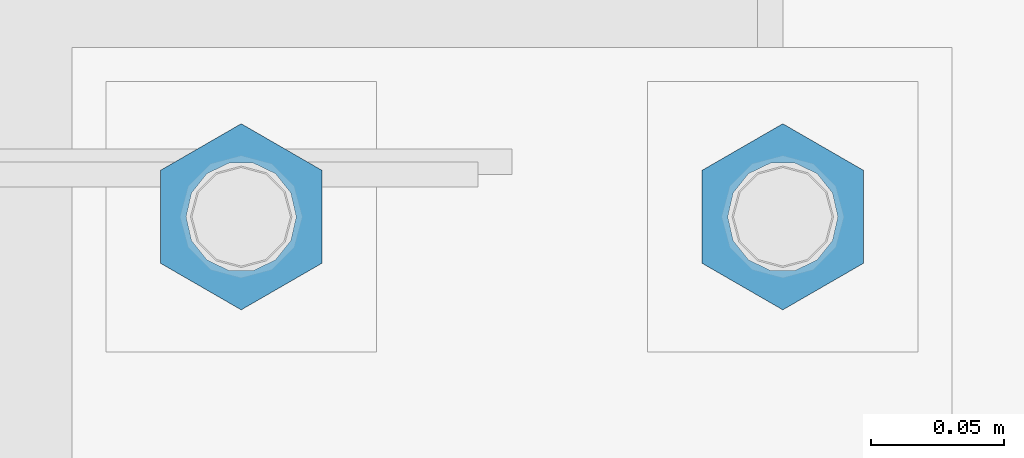
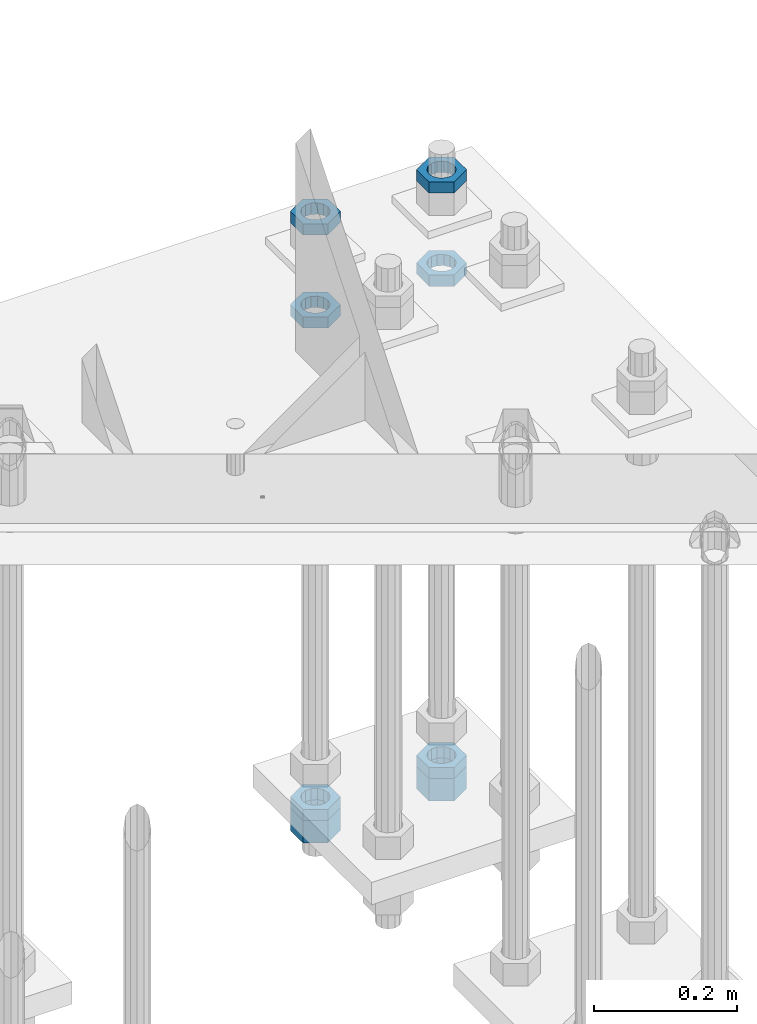
# One storey, part 2967 of 3843: 8 beams, 1 element without a shape of its own.
"""IFC2X3 building model written with IfcOpenShell, lengths in millimetres."""

from ifc_helpers import new_model, si_unit, frame, origin_with_axes, place, context, subcontext, project, spatial, faceted_brep, material, type_object, element, aggregate, save


model = new_model("IFC2X3")

# Units and contexts
model_context = context("Model", 3, precision=1e-05, world=origin_with_axes())
body_context = subcontext(model_context, "Body", "Model", "MODEL_VIEW")
ifc_project = project(units=[si_unit("LENGTHUNIT", "METRE", prefix="MILLI"), si_unit("AREAUNIT", "SQUARE_METRE"), si_unit("VOLUMEUNIT", "CUBIC_METRE"), si_unit("MASSUNIT", "GRAM", prefix="KILO"), si_unit("TIMEUNIT", "SECOND"), si_unit("PLANEANGLEUNIT", "RADIAN"), si_unit("SOLIDANGLEUNIT", "STERADIAN"), si_unit("THERMODYNAMICTEMPERATUREUNIT", "DEGREE_CELSIUS"), si_unit("LUMINOUSINTENSITYUNIT", "LUMEN")], contexts=[model_context])

# Site, building, storey
site_placement = place(None, origin_with_axes())
site = spatial("IfcSite", under=ifc_project, at=site_placement, CompositionType="ELEMENT")
building_placement = place(site_placement, origin_with_axes())
building = spatial("IfcBuilding", under=site, at=building_placement, Name="Undefined", CompositionType="ELEMENT")
storey_placement = place(building_placement, origin_with_axes())
storey = spatial("IfcBuildingStorey", under=building, at=storey_placement, Name="Undefined", CompositionType="ELEMENT", Elevation=0.0)

# Assembly, beams
assembly_placement = place(storey_placement, origin_with_axes())
assembly = element("IfcElementAssembly", 1, at=assembly_placement, inside=storey, Name="TEMPLATE", AssemblyPlace="NOTDEFINED", PredefinedType="RIGID_FRAME")
ifc_material = material(Name="STEEL/A572-50")
beam_type_1 = type_object("IfcBeamType", Name="1-1/2_HEAVY_HEX_NUT", PredefinedType="NOTDEFINED")
beam_1_placement = place(assembly_placement, frame((86156.8, 104940.1, 28746.45), z_axis=(-1.0, 0.0, 0.0), x_axis=(0.0, 0.0, -1.0)))
beam_1 = element("IfcBeam", 2, at=beam_1_placement, type_object=beam_type_1, material=ifc_material, Name="NUT", ObjectType="1-1/2_HEAVY_HEX_NUT", context=body_context, shape_type="Brep", body=[
    faceted_brep([(0.0, -34.9199981689453, 0.0), (0.0, -17.4599990844727, -30.25), (38.0999999999985, -17.4599990844727, -30.25), (38.0999999999985, -34.9199981689453, 0.0), (0.0, 17.4599990844727, -30.25), (38.0999999999985, 17.4599990844727, -30.25), (0.0, 34.9199981689453, 0.0), (38.0999999999985, 34.9199981689453, 0.0), (0.0, 17.4599990844727, 30.25), (38.0999999999985, 17.4599990844727, 30.25), (0.0, -17.4599990844727, 30.25), (38.0999999999985, -17.4599990844727, 30.25), (0.0, 0.0, 20.6399993896484), (0.0, 8.9553601105581, 18.5959968835959), (38.0999999999985, 8.9553601105581, 18.5959968835959), (38.0999999999985, 0.0, 20.6399993896484), (0.0, 16.1370013209525, 12.8688291298167), (38.0999999999985, 16.1370013209525, 12.8688291298167), (0.0, 20.1225115123816, 4.59283194104501), (38.0999999999985, 20.1225115123816, 4.59283194104501), (0.0, 20.1225115123816, -4.59283194104501), (38.0999999999985, 20.1225115123816, -4.59283194104501), (0.0, 16.1370013209525, -12.8688291298167), (38.0999999999985, 16.1370013209525, -12.8688291298167), (0.0, 8.9553601105581, -18.5959968835959), (38.0999999999985, 8.9553601105581, -18.5959968835959), (0.0, 0.0, -20.6399993896484), (38.0999999999985, 0.0, -20.6399993896484), (0.0, -8.9553601105581, -18.5959968835959), (38.0999999999985, -8.9553601105581, -18.5959968835959), (0.0, -16.1370013209525, -12.8688291298167), (38.0999999999985, -16.1370013209525, -12.8688291298167), (0.0, -20.1225115123816, -4.59283194104501), (38.0999999999985, -20.1225115123816, -4.59283194104501), (0.0, -20.1225115123816, 4.59283194104501), (38.0999999999985, -20.1225115123816, 4.59283194104501), (0.0, -16.1370013209525, 12.8688291298167), (38.0999999999985, -16.1370013209525, 12.8688291298167), (0.0, -8.9553601105581, 18.5959968835959), (38.0999999999985, -8.9553601105581, 18.5959968835959)], [[[0, 1, 2, 3]], [[1, 4, 5, 2]], [[4, 6, 7, 5]], [[6, 8, 9, 7]], [[8, 10, 11, 9]], [[10, 0, 3, 11]], [[12, 13, 14, 15]], [[13, 16, 17, 14]], [[16, 18, 19, 17]], [[18, 20, 21, 19]], [[20, 22, 23, 21]], [[22, 24, 25, 23]], [[24, 26, 27, 25]], [[26, 28, 29, 27]], [[28, 30, 31, 29]], [[30, 32, 33, 31]], [[32, 34, 35, 33]], [[34, 36, 37, 35]], [[36, 38, 39, 37]], [[38, 12, 15, 39]], [[5, 7, 9, 11, 3, 2], [17, 19, 21, 23, 25, 27, 29, 31, 33, 35, 37, 39, 15, 14]], [[10, 8, 6, 4, 1, 0], [38, 36, 34, 32, 30, 28, 26, 24, 22, 20, 18, 16, 13, 12]]]),
])
beam_2_placement = place(assembly_placement, frame((85953.6, 104940.1, 28746.45), z_axis=(-1.0, 0.0, 0.0), x_axis=(0.0, 0.0, -1.0)))
beam_2 = element("IfcBeam", 3, at=beam_2_placement, type_object=beam_type_1, material=ifc_material, Name="NUT", ObjectType="1-1/2_HEAVY_HEX_NUT", context=body_context, shape_type="Brep", body=[
    faceted_brep([(0.0, -34.9199981689453, 0.0), (0.0, -17.4599990844727, -30.25), (38.0999999999985, -17.4599990844727, -30.25), (38.0999999999985, -34.9199981689453, 0.0), (0.0, 17.4599990844727, -30.25), (38.0999999999985, 17.4599990844727, -30.25), (0.0, 34.9199981689453, 0.0), (38.0999999999985, 34.9199981689453, 0.0), (0.0, 17.4599990844727, 30.25), (38.0999999999985, 17.4599990844727, 30.25), (0.0, -17.4599990844727, 30.25), (38.0999999999985, -17.4599990844727, 30.25), (0.0, 0.0, 20.6399993896484), (0.0, 8.9553601105581, 18.5959968835959), (38.0999999999985, 8.9553601105581, 18.5959968835959), (38.0999999999985, 0.0, 20.6399993896484), (0.0, 16.1370013209525, 12.8688291298167), (38.0999999999985, 16.1370013209525, 12.8688291298167), (0.0, 20.1225115123816, 4.59283194104501), (38.0999999999985, 20.1225115123816, 4.59283194104501), (0.0, 20.1225115123816, -4.59283194104501), (38.0999999999985, 20.1225115123816, -4.59283194104501), (0.0, 16.1370013209525, -12.8688291298167), (38.0999999999985, 16.1370013209525, -12.8688291298167), (0.0, 8.9553601105581, -18.5959968835959), (38.0999999999985, 8.9553601105581, -18.5959968835959), (0.0, 0.0, -20.6399993896484), (38.0999999999985, 0.0, -20.6399993896484), (0.0, -8.9553601105581, -18.5959968835959), (38.0999999999985, -8.9553601105581, -18.5959968835959), (0.0, -16.1370013209525, -12.8688291298167), (38.0999999999985, -16.1370013209525, -12.8688291298167), (0.0, -20.1225115123816, -4.59283194104501), (38.0999999999985, -20.1225115123816, -4.59283194104501), (0.0, -20.1225115123816, 4.59283194104501), (38.0999999999985, -20.1225115123816, 4.59283194104501), (0.0, -16.1370013209525, 12.8688291298167), (38.0999999999985, -16.1370013209525, 12.8688291298167), (0.0, -8.9553601105581, 18.5959968835959), (38.0999999999985, -8.9553601105581, 18.5959968835959)], [[[0, 1, 2, 3]], [[1, 4, 5, 2]], [[4, 6, 7, 5]], [[6, 8, 9, 7]], [[8, 10, 11, 9]], [[10, 0, 3, 11]], [[12, 13, 14, 15]], [[13, 16, 17, 14]], [[16, 18, 19, 17]], [[18, 20, 21, 19]], [[20, 22, 23, 21]], [[22, 24, 25, 23]], [[24, 26, 27, 25]], [[26, 28, 29, 27]], [[28, 30, 31, 29]], [[30, 32, 33, 31]], [[32, 34, 35, 33]], [[34, 36, 37, 35]], [[36, 38, 39, 37]], [[38, 12, 15, 39]], [[5, 7, 9, 11, 3, 2], [17, 19, 21, 23, 25, 27, 29, 31, 33, 35, 37, 39, 15, 14]], [[10, 8, 6, 4, 1, 0], [38, 36, 34, 32, 30, 28, 26, 24, 22, 20, 18, 16, 13, 12]]]),
])
beam_type_2 = type_object("IfcBeamType", Name="1-1/2_HALF_NUT", PredefinedType="NOTDEFINED")
beam_3_placement = place(assembly_placement, frame((86156.8, 104940.1, 29603.7), z_axis=(-1.0, 0.0, 0.0), x_axis=(0.0, 0.0, -1.0)))
beam_3 = element("IfcBeam", 4, at=beam_3_placement, type_object=beam_type_2, material=ifc_material, Name="NUT", ObjectType="1-1/2_HALF_NUT", context=body_context, shape_type="Brep", body=[
    faceted_brep([(0.0, -34.9199981689453, 0.0), (0.0, -17.4599990844727, -30.25), (19.0500000000029, -17.4599990844727, -30.25), (19.0500000000029, -34.9199981689453, 0.0), (0.0, 17.4599990844727, -30.25), (19.0500000000029, 17.4599990844727, -30.25), (0.0, 34.9199981689453, 0.0), (19.0500000000029, 34.9199981689453, 0.0), (0.0, 17.4599990844727, 30.25), (19.0500000000029, 17.4599990844727, 30.25), (0.0, -17.4599990844727, 30.25), (19.0500000000029, -17.4599990844727, 30.25), (0.0, 0.0, 20.6399993896484), (0.0, 8.9553601105581, 18.5959968835959), (19.0500000000029, 8.95536011056538, 18.5959968835959), (19.0500000000029, 0.0, 20.6399993896484), (0.0, 16.1370013209525, 12.8688291298167), (19.0500000000029, 16.1370013209489, 12.8688291298167), (0.0, 20.1225115123816, 4.59283194104501), (19.0500000000029, 20.1225115123852, 4.59283194104501), (0.0, 20.1225115123816, -4.59283194104501), (19.0500000000029, 20.1225115123852, -4.59283194104501), (0.0, 16.1370013209525, -12.8688291298167), (19.0500000000029, 16.1370013209489, -12.8688291298167), (0.0, 8.9553601105581, -18.5959968835959), (19.0500000000029, 8.95536011056538, -18.5959968835959), (0.0, 0.0, -20.6399993896484), (19.0500000000029, 0.0, -20.6399993896484), (0.0, -8.9553601105581, -18.5959968835959), (19.0500000000029, -8.95536011056538, -18.5959968835959), (0.0, -16.1370013209525, -12.8688291298167), (19.0500000000029, -16.1370013209489, -12.8688291298167), (0.0, -20.1225115123816, -4.59283194104501), (19.0500000000029, -20.1225115123852, -4.59283194104501), (0.0, -20.1225115123816, 4.59283194104501), (19.0500000000029, -20.1225115123852, 4.59283194104501), (0.0, -16.1370013209525, 12.8688291298167), (19.0500000000029, -16.1370013209489, 12.8688291298167), (0.0, -8.9553601105581, 18.5959968835959), (19.0500000000029, -8.95536011056538, 18.5959968835959)], [[[0, 1, 2, 3]], [[1, 4, 5, 2]], [[4, 6, 7, 5]], [[6, 8, 9, 7]], [[8, 10, 11, 9]], [[10, 0, 3, 11]], [[12, 13, 14, 15]], [[13, 16, 17, 14]], [[16, 18, 19, 17]], [[18, 20, 21, 19]], [[20, 22, 23, 21]], [[22, 24, 25, 23]], [[24, 26, 27, 25]], [[26, 28, 29, 27]], [[28, 30, 31, 29]], [[30, 32, 33, 31]], [[32, 34, 35, 33]], [[34, 36, 37, 35]], [[36, 38, 39, 37]], [[38, 12, 15, 39]], [[5, 7, 9, 11, 3, 2], [17, 19, 21, 23, 25, 27, 29, 31, 33, 35, 37, 39, 15, 14]], [[10, 8, 6, 4, 1, 0], [38, 36, 34, 32, 30, 28, 26, 24, 22, 20, 18, 16, 13, 12]]]),
])
beam_4_placement = place(assembly_placement, frame((85953.6, 104940.1, 29603.7), z_axis=(-1.0, 0.0, 0.0), x_axis=(0.0, 0.0, -1.0)))
beam_4 = element("IfcBeam", 5, at=beam_4_placement, type_object=beam_type_2, material=ifc_material, Name="NUT", ObjectType="1-1/2_HALF_NUT", context=body_context, shape_type="Brep", body=[
    faceted_brep([(0.0, -34.9199981689453, 0.0), (0.0, -17.4599990844727, -30.25), (19.0500000000029, -17.4599990844727, -30.25), (19.0500000000029, -34.9199981689453, 0.0), (0.0, 17.4599990844727, -30.25), (19.0500000000029, 17.4599990844727, -30.25), (0.0, 34.9199981689453, 0.0), (19.0500000000029, 34.9199981689453, 0.0), (0.0, 17.4599990844727, 30.25), (19.0500000000029, 17.4599990844727, 30.25), (0.0, -17.4599990844727, 30.25), (19.0500000000029, -17.4599990844727, 30.25), (0.0, 0.0, 20.6399993896484), (0.0, 8.9553601105581, 18.5959968835959), (19.0500000000029, 8.95536011056538, 18.5959968835959), (19.0500000000029, 0.0, 20.6399993896484), (0.0, 16.1370013209525, 12.8688291298167), (19.0500000000029, 16.1370013209489, 12.8688291298167), (0.0, 20.1225115123816, 4.59283194104501), (19.0500000000029, 20.1225115123852, 4.59283194104501), (0.0, 20.1225115123816, -4.59283194104501), (19.0500000000029, 20.1225115123852, -4.59283194104501), (0.0, 16.1370013209525, -12.8688291298167), (19.0500000000029, 16.1370013209489, -12.8688291298167), (0.0, 8.9553601105581, -18.5959968835959), (19.0500000000029, 8.95536011056538, -18.5959968835959), (0.0, 0.0, -20.6399993896484), (19.0500000000029, 0.0, -20.6399993896484), (0.0, -8.9553601105581, -18.5959968835959), (19.0500000000029, -8.95536011056538, -18.5959968835959), (0.0, -16.1370013209525, -12.8688291298167), (19.0500000000029, -16.1370013209489, -12.8688291298167), (0.0, -20.1225115123816, -4.59283194104501), (19.0500000000029, -20.1225115123852, -4.59283194104501), (0.0, -20.1225115123816, 4.59283194104501), (19.0500000000029, -20.1225115123852, 4.59283194104501), (0.0, -16.1370013209525, 12.8688291298167), (19.0500000000029, -16.1370013209489, 12.8688291298167), (0.0, -8.9553601105581, 18.5959968835959), (19.0500000000029, -8.95536011056538, 18.5959968835959)], [[[0, 1, 2, 3]], [[1, 4, 5, 2]], [[4, 6, 7, 5]], [[6, 8, 9, 7]], [[8, 10, 11, 9]], [[10, 0, 3, 11]], [[12, 13, 14, 15]], [[13, 16, 17, 14]], [[16, 18, 19, 17]], [[18, 20, 21, 19]], [[20, 22, 23, 21]], [[22, 24, 25, 23]], [[24, 26, 27, 25]], [[26, 28, 29, 27]], [[28, 30, 31, 29]], [[30, 32, 33, 31]], [[32, 34, 35, 33]], [[34, 36, 37, 35]], [[36, 38, 39, 37]], [[38, 12, 15, 39]], [[5, 7, 9, 11, 3, 2], [17, 19, 21, 23, 25, 27, 29, 31, 33, 35, 37, 39, 15, 14]], [[10, 8, 6, 4, 1, 0], [38, 36, 34, 32, 30, 28, 26, 24, 22, 20, 18, 16, 13, 12]]]),
])
beam_5_placement = place(assembly_placement, frame((86156.8, 104940.1, 28765.5), z_axis=(-1.0, 0.0, 0.0), x_axis=(0.0, 0.0, -1.0)))
beam_5 = element("IfcBeam", 6, at=beam_5_placement, type_object=beam_type_2, material=ifc_material, Name="NUT", ObjectType="1-1/2_HALF_NUT", context=body_context, shape_type="Brep", body=[
    faceted_brep([(0.0, -34.9199981689453, 0.0), (0.0, -17.4599990844727, -30.25), (19.0500000000029, -17.4599990844727, -30.25), (19.0500000000029, -34.9199981689453, 0.0), (0.0, 17.4599990844727, -30.25), (19.0500000000029, 17.4599990844727, -30.25), (0.0, 34.9199981689453, 0.0), (19.0500000000029, 34.9199981689453, 0.0), (0.0, 17.4599990844727, 30.25), (19.0500000000029, 17.4599990844727, 30.25), (0.0, -17.4599990844727, 30.25), (19.0500000000029, -17.4599990844727, 30.25), (0.0, 0.0, 20.6399993896484), (0.0, 8.9553601105581, 18.5959968835959), (19.0500000000029, 8.95536011056538, 18.5959968835959), (19.0500000000029, 0.0, 20.6399993896484), (0.0, 16.1370013209525, 12.8688291298167), (19.0500000000029, 16.1370013209489, 12.8688291298167), (0.0, 20.1225115123816, 4.59283194104501), (19.0500000000029, 20.1225115123852, 4.59283194104501), (0.0, 20.1225115123816, -4.59283194104501), (19.0500000000029, 20.1225115123852, -4.59283194104501), (0.0, 16.1370013209525, -12.8688291298167), (19.0500000000029, 16.1370013209489, -12.8688291298167), (0.0, 8.9553601105581, -18.5959968835959), (19.0500000000029, 8.95536011056538, -18.5959968835959), (0.0, 0.0, -20.6399993896484), (19.0500000000029, 0.0, -20.6399993896484), (0.0, -8.9553601105581, -18.5959968835959), (19.0500000000029, -8.95536011056538, -18.5959968835959), (0.0, -16.1370013209525, -12.8688291298167), (19.0500000000029, -16.1370013209489, -12.8688291298167), (0.0, -20.1225115123816, -4.59283194104501), (19.0500000000029, -20.1225115123852, -4.59283194104501), (0.0, -20.1225115123816, 4.59283194104501), (19.0500000000029, -20.1225115123852, 4.59283194104501), (0.0, -16.1370013209525, 12.8688291298167), (19.0500000000029, -16.1370013209489, 12.8688291298167), (0.0, -8.9553601105581, 18.5959968835959), (19.0500000000029, -8.95536011056538, 18.5959968835959)], [[[0, 1, 2, 3]], [[1, 4, 5, 2]], [[4, 6, 7, 5]], [[6, 8, 9, 7]], [[8, 10, 11, 9]], [[10, 0, 3, 11]], [[12, 13, 14, 15]], [[13, 16, 17, 14]], [[16, 18, 19, 17]], [[18, 20, 21, 19]], [[20, 22, 23, 21]], [[22, 24, 25, 23]], [[24, 26, 27, 25]], [[26, 28, 29, 27]], [[28, 30, 31, 29]], [[30, 32, 33, 31]], [[32, 34, 35, 33]], [[34, 36, 37, 35]], [[36, 38, 39, 37]], [[38, 12, 15, 39]], [[5, 7, 9, 11, 3, 2], [17, 19, 21, 23, 25, 27, 29, 31, 33, 35, 37, 39, 15, 14]], [[10, 8, 6, 4, 1, 0], [38, 36, 34, 32, 30, 28, 26, 24, 22, 20, 18, 16, 13, 12]]]),
])
beam_6_placement = place(assembly_placement, frame((86156.8, 104940.1, 29762.45), z_axis=(-1.0, 0.0, 0.0), x_axis=(0.0, 0.0, -1.0)))
beam_6 = element("IfcBeam", 7, at=beam_6_placement, type_object=beam_type_2, material=ifc_material, Name="NUT", ObjectType="1-1/2_HALF_NUT", context=body_context, shape_type="Brep", body=[
    faceted_brep([(0.0, -34.9199981689453, 0.0), (0.0, -17.4599990844727, -30.25), (19.0500000000029, -17.4599990844727, -30.25), (19.0500000000029, -34.9199981689453, 0.0), (0.0, 17.4599990844727, -30.25), (19.0500000000029, 17.4599990844727, -30.25), (0.0, 34.9199981689453, 0.0), (19.0500000000029, 34.9199981689453, 0.0), (0.0, 17.4599990844727, 30.25), (19.0500000000029, 17.4599990844727, 30.25), (0.0, -17.4599990844727, 30.25), (19.0500000000029, -17.4599990844727, 30.25), (0.0, 0.0, 20.6399993896484), (0.0, 8.9553601105581, 18.5959968835959), (19.0500000000029, 8.95536011056538, 18.5959968835959), (19.0500000000029, 0.0, 20.6399993896484), (0.0, 16.1370013209525, 12.8688291298167), (19.0500000000029, 16.1370013209489, 12.8688291298167), (0.0, 20.1225115123816, 4.59283194104501), (19.0500000000029, 20.1225115123852, 4.59283194104501), (0.0, 20.1225115123816, -4.59283194104501), (19.0500000000029, 20.1225115123852, -4.59283194104501), (0.0, 16.1370013209525, -12.8688291298167), (19.0500000000029, 16.1370013209489, -12.8688291298167), (0.0, 8.9553601105581, -18.5959968835959), (19.0500000000029, 8.95536011056538, -18.5959968835959), (0.0, 0.0, -20.6399993896484), (19.0500000000029, 0.0, -20.6399993896484), (0.0, -8.9553601105581, -18.5959968835959), (19.0500000000029, -8.95536011056538, -18.5959968835959), (0.0, -16.1370013209525, -12.8688291298167), (19.0500000000029, -16.1370013209489, -12.8688291298167), (0.0, -20.1225115123816, -4.59283194104501), (19.0500000000029, -20.1225115123852, -4.59283194104501), (0.0, -20.1225115123816, 4.59283194104501), (19.0500000000029, -20.1225115123852, 4.59283194104501), (0.0, -16.1370013209525, 12.8688291298167), (19.0500000000029, -16.1370013209489, 12.8688291298167), (0.0, -8.9553601105581, 18.5959968835959), (19.0500000000029, -8.95536011056538, 18.5959968835959)], [[[0, 1, 2, 3]], [[1, 4, 5, 2]], [[4, 6, 7, 5]], [[6, 8, 9, 7]], [[8, 10, 11, 9]], [[10, 0, 3, 11]], [[12, 13, 14, 15]], [[13, 16, 17, 14]], [[16, 18, 19, 17]], [[18, 20, 21, 19]], [[20, 22, 23, 21]], [[22, 24, 25, 23]], [[24, 26, 27, 25]], [[26, 28, 29, 27]], [[28, 30, 31, 29]], [[30, 32, 33, 31]], [[32, 34, 35, 33]], [[34, 36, 37, 35]], [[36, 38, 39, 37]], [[38, 12, 15, 39]], [[5, 7, 9, 11, 3, 2], [17, 19, 21, 23, 25, 27, 29, 31, 33, 35, 37, 39, 15, 14]], [[10, 8, 6, 4, 1, 0], [38, 36, 34, 32, 30, 28, 26, 24, 22, 20, 18, 16, 13, 12]]]),
])
beam_7_placement = place(assembly_placement, frame((85953.6, 104940.1, 28765.5), z_axis=(-1.0, 0.0, 0.0), x_axis=(0.0, 0.0, -1.0)))
beam_7 = element("IfcBeam", 8, at=beam_7_placement, type_object=beam_type_2, material=ifc_material, Name="NUT", ObjectType="1-1/2_HALF_NUT", context=body_context, shape_type="Brep", body=[
    faceted_brep([(0.0, -34.9199981689453, 0.0), (0.0, -17.4599990844727, -30.25), (19.0500000000029, -17.4599990844727, -30.25), (19.0500000000029, -34.9199981689453, 0.0), (0.0, 17.4599990844727, -30.25), (19.0500000000029, 17.4599990844727, -30.25), (0.0, 34.9199981689453, 0.0), (19.0500000000029, 34.9199981689453, 0.0), (0.0, 17.4599990844727, 30.25), (19.0500000000029, 17.4599990844727, 30.25), (0.0, -17.4599990844727, 30.25), (19.0500000000029, -17.4599990844727, 30.25), (0.0, 0.0, 20.6399993896484), (0.0, 8.9553601105581, 18.5959968835959), (19.0500000000029, 8.95536011056538, 18.5959968835959), (19.0500000000029, 0.0, 20.6399993896484), (0.0, 16.1370013209525, 12.8688291298167), (19.0500000000029, 16.1370013209489, 12.8688291298167), (0.0, 20.1225115123816, 4.59283194104501), (19.0500000000029, 20.1225115123852, 4.59283194104501), (0.0, 20.1225115123816, -4.59283194104501), (19.0500000000029, 20.1225115123852, -4.59283194104501), (0.0, 16.1370013209525, -12.8688291298167), (19.0500000000029, 16.1370013209489, -12.8688291298167), (0.0, 8.9553601105581, -18.5959968835959), (19.0500000000029, 8.95536011056538, -18.5959968835959), (0.0, 0.0, -20.6399993896484), (19.0500000000029, 0.0, -20.6399993896484), (0.0, -8.9553601105581, -18.5959968835959), (19.0500000000029, -8.95536011056538, -18.5959968835959), (0.0, -16.1370013209525, -12.8688291298167), (19.0500000000029, -16.1370013209489, -12.8688291298167), (0.0, -20.1225115123816, -4.59283194104501), (19.0500000000029, -20.1225115123852, -4.59283194104501), (0.0, -20.1225115123816, 4.59283194104501), (19.0500000000029, -20.1225115123852, 4.59283194104501), (0.0, -16.1370013209525, 12.8688291298167), (19.0500000000029, -16.1370013209489, 12.8688291298167), (0.0, -8.9553601105581, 18.5959968835959), (19.0500000000029, -8.95536011056538, 18.5959968835959)], [[[0, 1, 2, 3]], [[1, 4, 5, 2]], [[4, 6, 7, 5]], [[6, 8, 9, 7]], [[8, 10, 11, 9]], [[10, 0, 3, 11]], [[12, 13, 14, 15]], [[13, 16, 17, 14]], [[16, 18, 19, 17]], [[18, 20, 21, 19]], [[20, 22, 23, 21]], [[22, 24, 25, 23]], [[24, 26, 27, 25]], [[26, 28, 29, 27]], [[28, 30, 31, 29]], [[30, 32, 33, 31]], [[32, 34, 35, 33]], [[34, 36, 37, 35]], [[36, 38, 39, 37]], [[38, 12, 15, 39]], [[5, 7, 9, 11, 3, 2], [17, 19, 21, 23, 25, 27, 29, 31, 33, 35, 37, 39, 15, 14]], [[10, 8, 6, 4, 1, 0], [38, 36, 34, 32, 30, 28, 26, 24, 22, 20, 18, 16, 13, 12]]]),
])
beam_8_placement = place(assembly_placement, frame((85953.6, 104940.1, 29762.45), z_axis=(-1.0, 0.0, 0.0), x_axis=(0.0, 0.0, -1.0)))
beam_8 = element("IfcBeam", 9, at=beam_8_placement, type_object=beam_type_2, material=ifc_material, Name="NUT", ObjectType="1-1/2_HALF_NUT", context=body_context, shape_type="Brep", body=[
    faceted_brep([(0.0, -34.9199981689453, 0.0), (0.0, -17.4599990844727, -30.25), (19.0500000000029, -17.4599990844727, -30.25), (19.0500000000029, -34.9199981689453, 0.0), (0.0, 17.4599990844727, -30.25), (19.0500000000029, 17.4599990844727, -30.25), (0.0, 34.9199981689453, 0.0), (19.0500000000029, 34.9199981689453, 0.0), (0.0, 17.4599990844727, 30.25), (19.0500000000029, 17.4599990844727, 30.25), (0.0, -17.4599990844727, 30.25), (19.0500000000029, -17.4599990844727, 30.25), (0.0, 0.0, 20.6399993896484), (0.0, 8.9553601105581, 18.5959968835959), (19.0500000000029, 8.95536011056538, 18.5959968835959), (19.0500000000029, 0.0, 20.6399993896484), (0.0, 16.1370013209525, 12.8688291298167), (19.0500000000029, 16.1370013209489, 12.8688291298167), (0.0, 20.1225115123816, 4.59283194104501), (19.0500000000029, 20.1225115123852, 4.59283194104501), (0.0, 20.1225115123816, -4.59283194104501), (19.0500000000029, 20.1225115123852, -4.59283194104501), (0.0, 16.1370013209525, -12.8688291298167), (19.0500000000029, 16.1370013209489, -12.8688291298167), (0.0, 8.9553601105581, -18.5959968835959), (19.0500000000029, 8.95536011056538, -18.5959968835959), (0.0, 0.0, -20.6399993896484), (19.0500000000029, 0.0, -20.6399993896484), (0.0, -8.9553601105581, -18.5959968835959), (19.0500000000029, -8.95536011056538, -18.5959968835959), (0.0, -16.1370013209525, -12.8688291298167), (19.0500000000029, -16.1370013209489, -12.8688291298167), (0.0, -20.1225115123816, -4.59283194104501), (19.0500000000029, -20.1225115123852, -4.59283194104501), (0.0, -20.1225115123816, 4.59283194104501), (19.0500000000029, -20.1225115123852, 4.59283194104501), (0.0, -16.1370013209525, 12.8688291298167), (19.0500000000029, -16.1370013209489, 12.8688291298167), (0.0, -8.9553601105581, 18.5959968835959), (19.0500000000029, -8.95536011056538, 18.5959968835959)], [[[0, 1, 2, 3]], [[1, 4, 5, 2]], [[4, 6, 7, 5]], [[6, 8, 9, 7]], [[8, 10, 11, 9]], [[10, 0, 3, 11]], [[12, 13, 14, 15]], [[13, 16, 17, 14]], [[16, 18, 19, 17]], [[18, 20, 21, 19]], [[20, 22, 23, 21]], [[22, 24, 25, 23]], [[24, 26, 27, 25]], [[26, 28, 29, 27]], [[28, 30, 31, 29]], [[30, 32, 33, 31]], [[32, 34, 35, 33]], [[34, 36, 37, 35]], [[36, 38, 39, 37]], [[38, 12, 15, 39]], [[5, 7, 9, 11, 3, 2], [17, 19, 21, 23, 25, 27, 29, 31, 33, 35, 37, 39, 15, 14]], [[10, 8, 6, 4, 1, 0], [38, 36, 34, 32, 30, 28, 26, 24, 22, 20, 18, 16, 13, 12]]]),
])
aggregate(assembly, [beam_3, beam_4, beam_5, beam_1, beam_6, beam_7, beam_2, beam_8])

save(model, "model.ifc")
